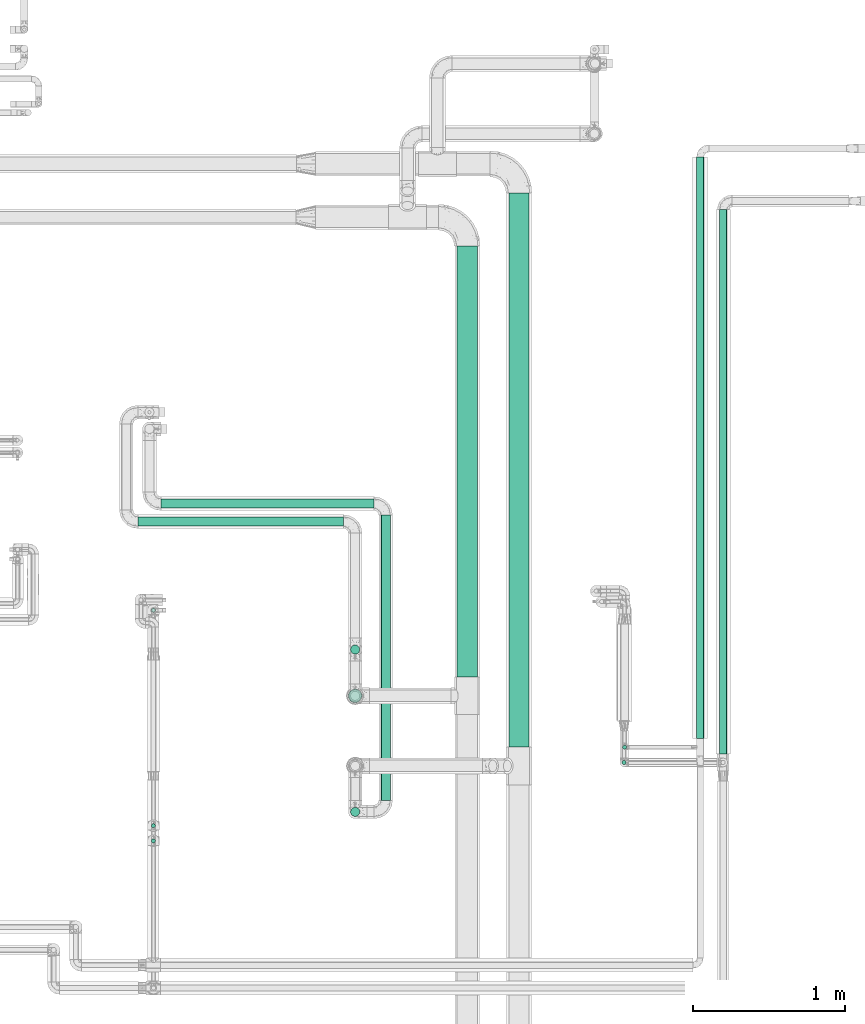
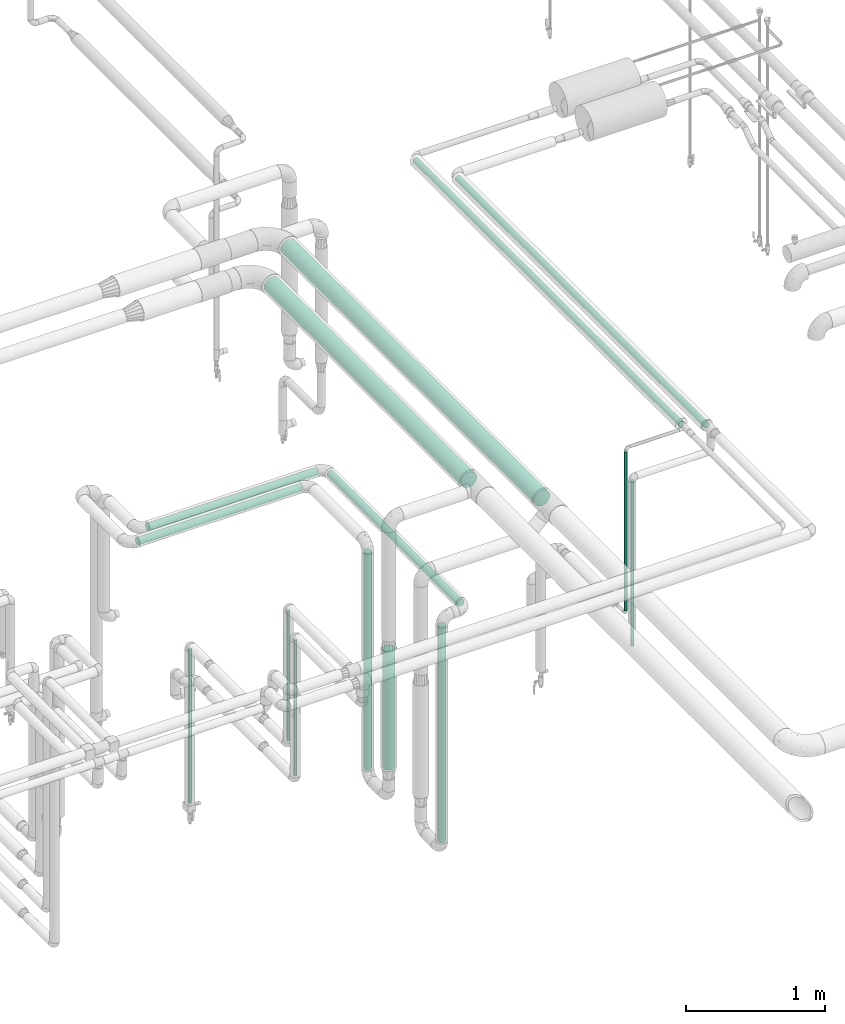
# One storey, part 522 of 827: 15 flow segments.
"""IFC2X3 building model written with IfcOpenShell, lengths in millimetres."""

from ifc_helpers import new_model, entity, si_unit, converted_unit, derived_unit, direction, frame, origin, origin_2d_with_axis, place, context, subcontext, project, spatial, circle, extrude, type_object, element, save


model = new_model("IFC2X3")

# Units and contexts
model_context = context("Model", 3, precision=0.01, world=origin(), true_north=direction((6.12303176911189e-17, 1.0)))
body_context = subcontext(model_context, "Body", "Model", "MODEL_VIEW")
ifc_project = project(units=[si_unit("LENGTHUNIT", "METRE", prefix="MILLI"), si_unit("AREAUNIT", "SQUARE_METRE"), si_unit("VOLUMEUNIT", "CUBIC_METRE"), converted_unit("PLANEANGLEUNIT", "DEGREE", entity("IfcRatioMeasure", 0.0174532925199433), si_unit("PLANEANGLEUNIT", "RADIAN"), dimensions=[0, 0, 0, 0, 0, 0, 0]), si_unit("MASSUNIT", "GRAM", prefix="KILO"), derived_unit("MASSDENSITYUNIT", [(si_unit("MASSUNIT", "GRAM", prefix="KILO"), 1), (si_unit("LENGTHUNIT", "METRE"), -3)]), derived_unit("MOMENTOFINERTIAUNIT", [(si_unit("LENGTHUNIT", "METRE"), 4)]), si_unit("TIMEUNIT", "SECOND"), si_unit("FREQUENCYUNIT", "HERTZ"), si_unit("THERMODYNAMICTEMPERATUREUNIT", "DEGREE_CELSIUS"), derived_unit("THERMALTRANSMITTANCEUNIT", [(si_unit("MASSUNIT", "GRAM", prefix="KILO"), 1), (si_unit("THERMODYNAMICTEMPERATUREUNIT", "KELVIN"), -1), (si_unit("TIMEUNIT", "SECOND"), -3)]), derived_unit("VOLUMETRICFLOWRATEUNIT", [(si_unit("LENGTHUNIT", "METRE"), 3), (si_unit("TIMEUNIT", "SECOND"), -1)]), derived_unit("MASSFLOWRATEUNIT", [(si_unit("MASSUNIT", "GRAM", prefix="KILO"), 1), (si_unit("TIMEUNIT", "SECOND"), -1)]), derived_unit("ROTATIONALFREQUENCYUNIT", [(si_unit("TIMEUNIT", "SECOND"), -1)]), si_unit("ELECTRICCURRENTUNIT", "AMPERE"), si_unit("ELECTRICVOLTAGEUNIT", "VOLT"), si_unit("POWERUNIT", "WATT"), si_unit("FORCEUNIT", "NEWTON", prefix="KILO"), si_unit("ILLUMINANCEUNIT", "LUX"), si_unit("LUMINOUSFLUXUNIT", "LUMEN"), si_unit("LUMINOUSINTENSITYUNIT", "CANDELA"), derived_unit("USERDEFINED", [(si_unit("MASSUNIT", "GRAM", prefix="KILO"), -1), (si_unit("LENGTHUNIT", "METRE"), -2), (si_unit("TIMEUNIT", "SECOND"), 3), (si_unit("LUMINOUSFLUXUNIT", "LUMEN"), 1)]), derived_unit("LINEARVELOCITYUNIT", [(si_unit("LENGTHUNIT", "METRE"), 1), (si_unit("TIMEUNIT", "SECOND"), -1)]), si_unit("PRESSUREUNIT", "PASCAL"), derived_unit("USERDEFINED", [(si_unit("LENGTHUNIT", "METRE"), -2), (si_unit("MASSUNIT", "GRAM", prefix="KILO"), 1), (si_unit("TIMEUNIT", "SECOND"), -2)]), derived_unit("LINEARFORCEUNIT", [(si_unit("MASSUNIT", "GRAM", prefix="KILO"), 1), (si_unit("LENGTHUNIT", "METRE"), 1), (si_unit("TIMEUNIT", "SECOND"), -2), (si_unit("LENGTHUNIT", "METRE"), -1)]), derived_unit("PLANARFORCEUNIT", [(si_unit("MASSUNIT", "GRAM", prefix="KILO"), 1), (si_unit("LENGTHUNIT", "METRE"), 1), (si_unit("TIMEUNIT", "SECOND"), -2), (si_unit("LENGTHUNIT", "METRE"), -2)])], contexts=[model_context])

# Site, building, storey
site_placement = place(None, origin())
site = spatial("IfcSite", under=ifc_project, at=site_placement, CompositionType="ELEMENT")
building_placement = place(site_placement, origin())
building = spatial("IfcBuilding", under=site, at=building_placement, CompositionType="ELEMENT")
storey_placement = place(building_placement, frame((0.0, 0.0, 28200.0)))
storey = spatial("IfcBuildingStorey", under=building, at=storey_placement, Name="08", CompositionType="ELEMENT", Elevation=28200.0)

# Flow segments
pipe_segment_type_1 = type_object("IfcPipeSegmentType", PredefinedType="NOTDEFINED")
flow_segment_1_placement = place(storey_placement, frame((22106.66, 10923.65, 2731.9)))
element("IfcFlowSegment", 1, at=flow_segment_1_placement, inside=storey, type_object=pipe_segment_type_1, context=body_context, shape_type="SweptSolid", body=[
    extrude(circle(Radius=66.5, at=origin_2d_with_axis()), frame((68.1, 0.0, 68.1), z_axis=(0.0, 1.0, -7.43771752301072e-07), x_axis=(1.0, 0.0, 0.0)), (0.0, 0.0, 1.0), 3636.14510383974),
])
flow_segment_2_placement = place(storey_placement, frame((21767.01, 11383.65, 2731.89)))
element("IfcFlowSegment", 2, at=flow_segment_2_placement, inside=storey, type_object=pipe_segment_type_1, context=body_context, shape_type="SweptSolid", body=[
    extrude(circle(Radius=66.5, at=origin_2d_with_axis()), frame((68.1, 0.0, 68.11), z_axis=(0.0, 1.0, -6.05126980004747e-06), x_axis=(1.0, 0.0, 0.0)), (0.0, 0.0, 1.0), 2826.34945677688),
])
pipe_segment_type_2 = type_object("IfcPipeSegmentType", PredefinedType="NOTDEFINED")
flow_segment_3_placement = place(storey_placement, frame((19826.0, 12489.23, 2368.4)))
element("IfcFlowSegment", 3, at=flow_segment_3_placement, inside=storey, type_object=pipe_segment_type_2, context=body_context, shape_type="SweptSolid", body=[
    extrude(circle(Radius=30.0, at=origin_2d_with_axis()), frame((0.0, 31.6, 31.6), z_axis=(1.0, 0.0, 0.0), x_axis=(0.0, -1.0, 0.0)), (0.0, 0.0, 1.0), 1398.24219517759),
])
flow_segment_4_placement = place(storey_placement, frame((19674.0, 12371.27, 2368.4)))
element("IfcFlowSegment", 4, at=flow_segment_4_placement, inside=storey, type_object=pipe_segment_type_2, context=body_context, shape_type="SweptSolid", body=[
    extrude(circle(Radius=30.0, at=origin_2d_with_axis()), frame((0.0, 31.6, 31.6), z_axis=(1.0, 0.0, 0.0), x_axis=(0.0, -1.0, 0.0)), (0.0, 0.0, 1.0), 1350.05414940568),
])
flow_segment_5_placement = place(storey_placement, frame((19761.27, 10392.59, 1833.68)))
element("IfcFlowSegment", 5, at=flow_segment_5_placement, inside=storey, type_object=pipe_segment_type_2, context=body_context, shape_type="SweptSolid", body=[
    extrude(circle(Radius=13.4, at=origin_2d_with_axis()), frame((15.0, 15.0, 0.0)), (0.0, 0.0, 1.0), 1134.54447482923),
])
flow_segment_6_placement = place(storey_placement, frame((19761.27, 10293.25, 1587.27)))
element("IfcFlowSegment", 6, at=flow_segment_6_placement, inside=storey, type_object=pipe_segment_type_2, context=body_context, shape_type="SweptSolid", body=[
    extrude(circle(Radius=13.4, at=origin_2d_with_axis()), frame((15.0, 15.0, 0.0)), (0.0, 0.0, 1.0), 1185.36019192896),
])
flow_segment_7_placement = place(storey_placement, frame((21268.65, 10574.33, 2368.4)))
element("IfcFlowSegment", 7, at=flow_segment_7_placement, inside=storey, type_object=pipe_segment_type_2, context=body_context, shape_type="SweptSolid", body=[
    extrude(circle(Radius=30.0, at=origin_2d_with_axis()), frame((31.6, 0.0, 31.6), z_axis=(0.0, 1.0, 0.0), x_axis=(-1.0, 0.0, 0.0)), (0.0, 0.0, 1.0), 1870.50000000001),
])
flow_segment_8_placement = place(storey_placement, frame((21068.46, 11531.27, 426.01)))
element("IfcFlowSegment", 8, at=flow_segment_8_placement, inside=storey, type_object=pipe_segment_type_2, context=body_context, shape_type="SweptSolid", body=[
    extrude(circle(Radius=30.0, at=origin_2d_with_axis()), frame((31.6, 31.6, 0.0)), (0.0, 0.0, 1.0), 1897.99009936313),
])
flow_segment_9_placement = place(storey_placement, frame((21068.7, 10466.73, 434.26)))
element("IfcFlowSegment", 9, at=flow_segment_9_placement, inside=storey, type_object=pipe_segment_type_2, context=body_context, shape_type="SweptSolid", body=[
    extrude(circle(Radius=30.0, at=origin_2d_with_axis()), frame((31.6, 31.6, 0.0)), (0.0, 0.0, 1.0), 1889.74450477698),
])
flow_segment_10_placement = place(storey_placement, frame((22853.3, 10907.28, 1576.5)))
element("IfcFlowSegment", 10, at=flow_segment_10_placement, inside=storey, type_object=pipe_segment_type_2, context=body_context, shape_type="SweptSolid", body=[
    extrude(circle(Radius=13.4, at=origin_2d_with_axis()), frame((15.0, 15.0, 0.0)), (0.0, 0.0, 1.0), 1392.52773047144),
])
flow_segment_11_placement = place(storey_placement, frame((22849.37, 10807.39, 1329.67)))
element("IfcFlowSegment", 11, at=flow_segment_11_placement, inside=storey, type_object=pipe_segment_type_2, context=body_context, shape_type="SweptSolid", body=[
    extrude(circle(Radius=13.4, at=origin_2d_with_axis()), frame((15.0, 15.0, 0.0)), (0.0, 0.0, 1.0), 1445.55000000002),
])
flow_segment_12_placement = place(storey_placement, frame((19761.27, 11806.06, 426.5)))
element("IfcFlowSegment", 12, at=flow_segment_12_placement, inside=storey, type_object=pipe_segment_type_2, context=body_context, shape_type="SweptSolid", body=[
    extrude(circle(Radius=13.4, at=origin_2d_with_axis()), frame((15.0, 15.0, 0.0)), (0.0, 0.0, 1.0), 1348.97714279943),
])
flow_segment_13_placement = place(storey_placement, frame((23337.72, 10979.27, 2972.53)))
element("IfcFlowSegment", 13, at=flow_segment_13_placement, inside=storey, type_object=pipe_segment_type_2, context=body_context, shape_type="SweptSolid", body=[
    extrude(circle(Radius=24.0, at=origin_2d_with_axis()), frame((25.6, 0.0, 25.6), z_axis=(0.0, 1.0, 0.0), x_axis=(-1.0, 0.0, 0.0)), (0.0, 0.0, 1.0), 3814.3307462866),
])
flow_segment_14_placement = place(storey_placement, frame((23488.79, 10879.39, 2970.89)))
element("IfcFlowSegment", 14, at=flow_segment_14_placement, inside=storey, type_object=pipe_segment_type_2, context=body_context, shape_type="SweptSolid", body=[
    extrude(circle(Radius=24.0, at=origin_2d_with_axis()), frame((25.6, 0.0, 25.6), z_axis=(0.0, 1.0, 0.0), x_axis=(-1.0, 0.0, 0.0)), (0.0, 0.0, 1.0), 3569.23335100453),
])
flow_segment_15_placement = place(storey_placement, frame((21054.21, 11213.8, 619.0)))
element("IfcFlowSegment", 15, at=flow_segment_15_placement, inside=storey, type_object=pipe_segment_type_2, context=body_context, shape_type="SweptSolid", body=[
    extrude(circle(Radius=44.25, at=origin_2d_with_axis()), frame((45.85, 45.85, 0.0)), (0.0, 0.0, 1.0), 1037.76432267898),
])

save(model, "model.ifc")
